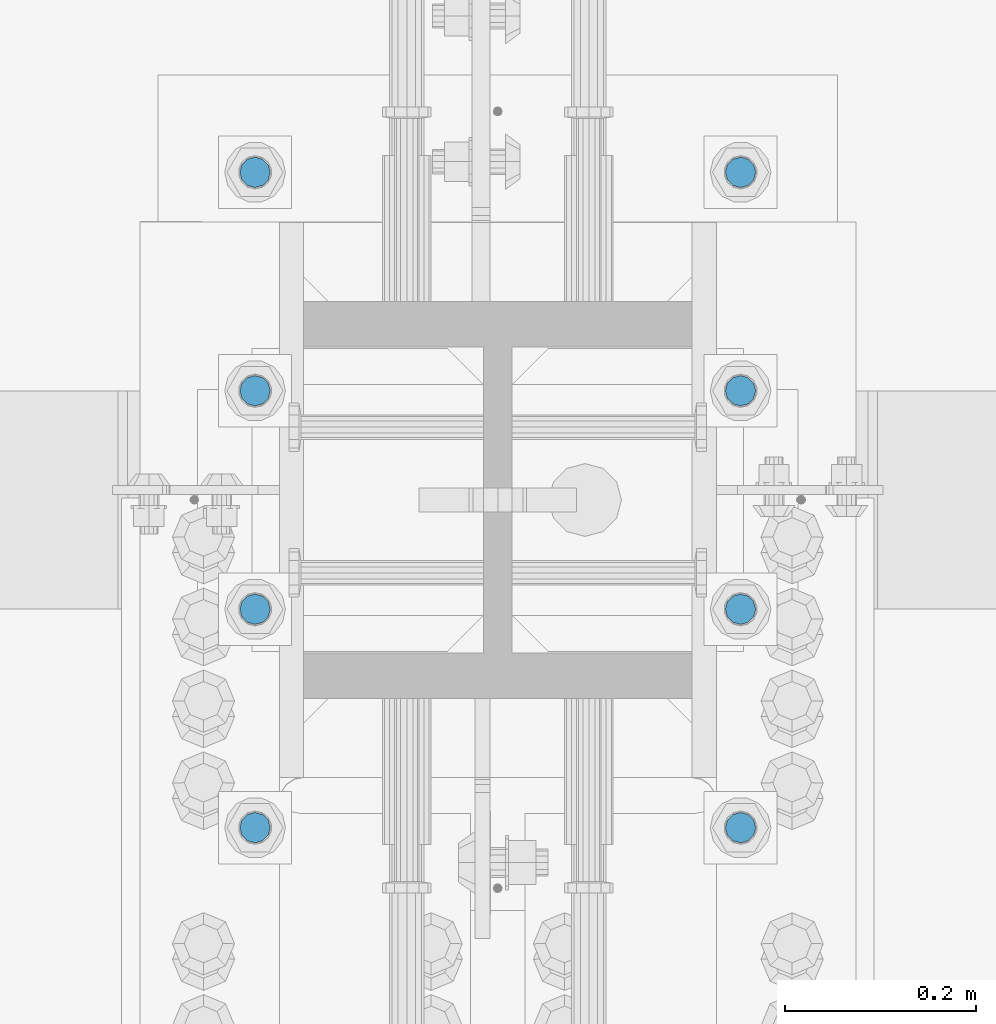
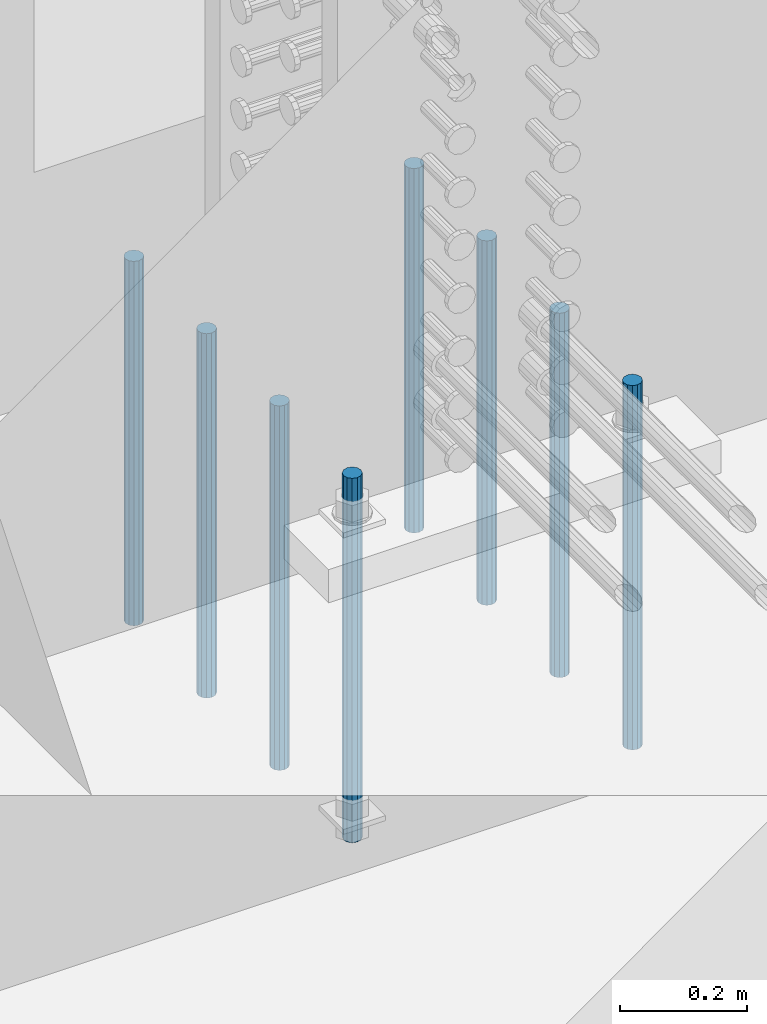
# One storey, part 939 of 1763: 8 columns, 1 element without a shape of its own.
"""IFC2X3 building model written with IfcOpenShell, lengths in millimetres."""

from ifc_helpers import new_model, si_unit, frame, origin_with_axes, place, context, subcontext, project, spatial, faceted_brep, material, type_object, element, aggregate, save


model = new_model("IFC2X3")

# Units and contexts
model_context = context("Model", 3, precision=1e-05, world=origin_with_axes())
body_context = subcontext(model_context, "Body", "Model", "MODEL_VIEW")
ifc_project = project(units=[si_unit("LENGTHUNIT", "METRE", prefix="MILLI"), si_unit("AREAUNIT", "SQUARE_METRE"), si_unit("VOLUMEUNIT", "CUBIC_METRE"), si_unit("MASSUNIT", "GRAM", prefix="KILO"), si_unit("TIMEUNIT", "SECOND"), si_unit("PLANEANGLEUNIT", "RADIAN"), si_unit("SOLIDANGLEUNIT", "STERADIAN"), si_unit("THERMODYNAMICTEMPERATUREUNIT", "DEGREE_CELSIUS"), si_unit("LUMINOUSINTENSITYUNIT", "LUMEN")], contexts=[model_context])

# Site, building, storey
site_placement = place(None, origin_with_axes())
site = spatial("IfcSite", under=ifc_project, at=site_placement, CompositionType="ELEMENT")
building_placement = place(site_placement, origin_with_axes())
building = spatial("IfcBuilding", under=site, at=building_placement, Name="Undefined", CompositionType="ELEMENT")
storey_placement = place(building_placement, origin_with_axes())
storey = spatial("IfcBuildingStorey", under=building, at=storey_placement, Name="Undefined", CompositionType="ELEMENT", Elevation=0.0)

# Assembly, columns
assembly_placement = place(storey_placement, origin_with_axes())
assembly = element("IfcElementAssembly", 1, at=assembly_placement, inside=storey, Name="TEMPLATE", AssemblyPlace="NOTDEFINED", PredefinedType="RIGID_FRAME")
ifc_material = material()
column_type = type_object("IfcColumnType", PredefinedType="NOTDEFINED")
column_1_placement = place(assembly_placement, frame((-24281.8372736984, 13347.6999999999, 4000.5), z_axis=(0.0, -1.0, 0.0), x_axis=(0.0, 0.0, -1.0)))
column_1 = element("IfcColumn", 2, at=column_1_placement, type_object=column_type, material=ifc_material, Name="ALL THREADED ROD", context=body_context, shape_type="Brep", body=[
    faceted_brep([(0.0, -15.875, 0.0), (0.0, -13.7481532850798, -7.9375), (698.499, -13.7481532850798, -7.9375), (698.499, -15.875, 0.0), (0.0, -7.9375, -13.748153285078), (698.499, -7.9375, -13.748153285078), (4.91792532185561e-12, 0.0, -15.875), (698.499, 0.0, -15.875), (0.0, 7.9375, -13.748153285078), (698.499, 7.9375, -13.748153285078), (0.0, 13.7481532850798, -7.9375), (698.499, 13.7481532850798, -7.9375), (0.0, 15.875, 0.0), (698.499, 15.875, 0.0), (0.0, 13.7481532850798, 7.9375), (698.499, 13.7481532850798, 7.9375), (0.0, 7.9375, 13.748153285078), (698.499, 7.9375, 13.748153285078), (-1.64518337079051e-12, 0.0, 15.875), (698.499, 0.0, 15.875), (0.0, -7.9375, 13.748153285078), (698.499, -7.9375, 13.748153285078), (0.0, -13.7481532850798, 7.9375), (698.499, -13.7481532850798, 7.9375)], [[[0, 1, 2, 3]], [[1, 4, 5, 2]], [[4, 6, 7, 5]], [[6, 8, 9, 7]], [[8, 10, 11, 9]], [[10, 12, 13, 11]], [[12, 14, 15, 13]], [[14, 16, 17, 15]], [[16, 18, 19, 17]], [[18, 20, 21, 19]], [[20, 22, 23, 21]], [[22, 0, 3, 23]], [[5, 7, 9, 11, 13, 15, 17, 19, 21, 23, 3, 2]], [[22, 20, 18, 16, 14, 12, 10, 8, 6, 4, 1, 0]]]),
])
column_2_placement = place(assembly_placement, frame((-23773.8372736984, 13347.6999999999, 4000.5), z_axis=(0.0, 1.0, 0.0), x_axis=(0.0, 0.0, -1.0)))
column_2 = element("IfcColumn", 3, at=column_2_placement, type_object=column_type, material=ifc_material, Name="ALL THREADED ROD", context=body_context, shape_type="Brep", body=[
    faceted_brep([(0.0, -15.875, 0.0), (0.0, -13.7481532850798, -7.9375), (698.499, -13.7481532850798, -7.9375), (698.499, -15.875, 0.0), (0.0, -7.9375, -13.748153285078), (698.499, -7.9375, -13.748153285078), (4.91792532185561e-12, 0.0, -15.875), (698.499, 0.0, -15.875), (0.0, 7.9375, -13.748153285078), (698.499, 7.9375, -13.748153285078), (0.0, 13.7481532850798, -7.9375), (698.499, 13.7481532850798, -7.9375), (0.0, 15.875, 0.0), (698.499, 15.875, 0.0), (0.0, 13.7481532850798, 7.9375), (698.499, 13.7481532850798, 7.9375), (0.0, 7.9375, 13.748153285078), (698.499, 7.9375, 13.748153285078), (-1.64518337079051e-12, 0.0, 15.875), (698.499, 0.0, 15.875), (0.0, -7.9375, 13.748153285078), (698.499, -7.9375, 13.748153285078), (0.0, -13.7481532850798, 7.9375), (698.499, -13.7481532850798, 7.9375)], [[[0, 1, 2, 3]], [[1, 4, 5, 2]], [[4, 6, 7, 5]], [[6, 8, 9, 7]], [[8, 10, 11, 9]], [[10, 12, 13, 11]], [[12, 14, 15, 13]], [[14, 16, 17, 15]], [[16, 18, 19, 17]], [[18, 20, 21, 19]], [[20, 22, 23, 21]], [[22, 0, 3, 23]], [[5, 7, 9, 11, 13, 15, 17, 19, 21, 23, 3, 2]], [[22, 20, 18, 16, 14, 12, 10, 8, 6, 4, 1, 0]]]),
])
column_3_placement = place(assembly_placement, frame((-24281.8372736984, 13576.2999999999, 4000.5), z_axis=(0.0, -1.0, 0.0), x_axis=(0.0, 0.0, -1.0)))
column_3 = element("IfcColumn", 4, at=column_3_placement, type_object=column_type, material=ifc_material, Name="ALL THREADED ROD", context=body_context, shape_type="Brep", body=[
    faceted_brep([(0.0, -15.875, 0.0), (0.0, -13.7481532850798, -7.9375), (698.499, -13.7481532850798, -7.9375), (698.499, -15.875, 0.0), (0.0, -7.9375, -13.748153285078), (698.499, -7.9375, -13.748153285078), (4.91792532185561e-12, 0.0, -15.875), (698.499, 0.0, -15.875), (0.0, 7.9375, -13.748153285078), (698.499, 7.9375, -13.748153285078), (0.0, 13.7481532850798, -7.9375), (698.499, 13.7481532850798, -7.9375), (0.0, 15.875, 0.0), (698.499, 15.875, 0.0), (0.0, 13.7481532850798, 7.9375), (698.499, 13.7481532850798, 7.9375), (0.0, 7.9375, 13.748153285078), (698.499, 7.9375, 13.748153285078), (-1.64518337079051e-12, 0.0, 15.875), (698.499, 0.0, 15.875), (0.0, -7.9375, 13.748153285078), (698.499, -7.9375, 13.748153285078), (0.0, -13.7481532850798, 7.9375), (698.499, -13.7481532850798, 7.9375)], [[[0, 1, 2, 3]], [[1, 4, 5, 2]], [[4, 6, 7, 5]], [[6, 8, 9, 7]], [[8, 10, 11, 9]], [[10, 12, 13, 11]], [[12, 14, 15, 13]], [[14, 16, 17, 15]], [[16, 18, 19, 17]], [[18, 20, 21, 19]], [[20, 22, 23, 21]], [[22, 0, 3, 23]], [[5, 7, 9, 11, 13, 15, 17, 19, 21, 23, 3, 2]], [[22, 20, 18, 16, 14, 12, 10, 8, 6, 4, 1, 0]]]),
])
column_4_placement = place(assembly_placement, frame((-23773.8372736984, 13576.2999999999, 4000.5), z_axis=(0.0, 1.0, 0.0), x_axis=(0.0, 0.0, -1.0)))
column_4 = element("IfcColumn", 5, at=column_4_placement, type_object=column_type, material=ifc_material, Name="ALL THREADED ROD", context=body_context, shape_type="Brep", body=[
    faceted_brep([(0.0, -15.875, 0.0), (0.0, -13.7481532850798, -7.9375), (698.499, -13.7481532850798, -7.9375), (698.499, -15.875, 0.0), (0.0, -7.9375, -13.748153285078), (698.499, -7.9375, -13.748153285078), (4.91792532185561e-12, 0.0, -15.875), (698.499, 0.0, -15.875), (0.0, 7.9375, -13.748153285078), (698.499, 7.9375, -13.748153285078), (0.0, 13.7481532850798, -7.9375), (698.499, 13.7481532850798, -7.9375), (0.0, 15.875, 0.0), (698.499, 15.875, 0.0), (0.0, 13.7481532850798, 7.9375), (698.499, 13.7481532850798, 7.9375), (0.0, 7.9375, 13.748153285078), (698.499, 7.9375, 13.748153285078), (-1.64518337079051e-12, 0.0, 15.875), (698.499, 0.0, 15.875), (0.0, -7.9375, 13.748153285078), (698.499, -7.9375, 13.748153285078), (0.0, -13.7481532850798, 7.9375), (698.499, -13.7481532850798, 7.9375)], [[[0, 1, 2, 3]], [[1, 4, 5, 2]], [[4, 6, 7, 5]], [[6, 8, 9, 7]], [[8, 10, 11, 9]], [[10, 12, 13, 11]], [[12, 14, 15, 13]], [[14, 16, 17, 15]], [[16, 18, 19, 17]], [[18, 20, 21, 19]], [[20, 22, 23, 21]], [[22, 0, 3, 23]], [[5, 7, 9, 11, 13, 15, 17, 19, 21, 23, 3, 2]], [[22, 20, 18, 16, 14, 12, 10, 8, 6, 4, 1, 0]]]),
])
column_5_placement = place(assembly_placement, frame((-24281.8372736984, 13804.8999999999, 4000.5), z_axis=(0.0, -1.0, 0.0), x_axis=(0.0, 0.0, -1.0)))
column_5 = element("IfcColumn", 6, at=column_5_placement, type_object=column_type, material=ifc_material, Name="ALL THREADED ROD", context=body_context, shape_type="Brep", body=[
    faceted_brep([(0.0, -15.875, 0.0), (0.0, -13.7481532850798, -7.9375), (698.499, -13.7481532850798, -7.9375), (698.499, -15.875, 0.0), (0.0, -7.9375, -13.748153285078), (698.499, -7.9375, -13.748153285078), (4.91792532185561e-12, 0.0, -15.875), (698.499, 0.0, -15.875), (0.0, 7.9375, -13.748153285078), (698.499, 7.9375, -13.748153285078), (0.0, 13.7481532850798, -7.9375), (698.499, 13.7481532850798, -7.9375), (0.0, 15.875, 0.0), (698.499, 15.875, 0.0), (0.0, 13.7481532850798, 7.9375), (698.499, 13.7481532850798, 7.9375), (0.0, 7.9375, 13.748153285078), (698.499, 7.9375, 13.748153285078), (-1.64518337079051e-12, 0.0, 15.875), (698.499, 0.0, 15.875), (0.0, -7.9375, 13.748153285078), (698.499, -7.9375, 13.748153285078), (0.0, -13.7481532850798, 7.9375), (698.499, -13.7481532850798, 7.9375)], [[[0, 1, 2, 3]], [[1, 4, 5, 2]], [[4, 6, 7, 5]], [[6, 8, 9, 7]], [[8, 10, 11, 9]], [[10, 12, 13, 11]], [[12, 14, 15, 13]], [[14, 16, 17, 15]], [[16, 18, 19, 17]], [[18, 20, 21, 19]], [[20, 22, 23, 21]], [[22, 0, 3, 23]], [[5, 7, 9, 11, 13, 15, 17, 19, 21, 23, 3, 2]], [[22, 20, 18, 16, 14, 12, 10, 8, 6, 4, 1, 0]]]),
])
column_6_placement = place(assembly_placement, frame((-23773.8372736984, 13804.8999999999, 4000.5), z_axis=(0.0, 1.0, 0.0), x_axis=(0.0, 0.0, -1.0)))
column_6 = element("IfcColumn", 7, at=column_6_placement, type_object=column_type, material=ifc_material, Name="ALL THREADED ROD", context=body_context, shape_type="Brep", body=[
    faceted_brep([(0.0, -15.875, 0.0), (0.0, -13.7481532850798, -7.9375), (698.499, -13.7481532850798, -7.9375), (698.499, -15.875, 0.0), (0.0, -7.9375, -13.748153285078), (698.499, -7.9375, -13.748153285078), (4.91792532185561e-12, 0.0, -15.875), (698.499, 0.0, -15.875), (0.0, 7.9375, -13.748153285078), (698.499, 7.9375, -13.748153285078), (0.0, 13.7481532850798, -7.9375), (698.499, 13.7481532850798, -7.9375), (0.0, 15.875, 0.0), (698.499, 15.875, 0.0), (0.0, 13.7481532850798, 7.9375), (698.499, 13.7481532850798, 7.9375), (0.0, 7.9375, 13.748153285078), (698.499, 7.9375, 13.748153285078), (-1.64518337079051e-12, 0.0, 15.875), (698.499, 0.0, 15.875), (0.0, -7.9375, 13.748153285078), (698.499, -7.9375, 13.748153285078), (0.0, -13.7481532850798, 7.9375), (698.499, -13.7481532850798, 7.9375)], [[[0, 1, 2, 3]], [[1, 4, 5, 2]], [[4, 6, 7, 5]], [[6, 8, 9, 7]], [[8, 10, 11, 9]], [[10, 12, 13, 11]], [[12, 14, 15, 13]], [[14, 16, 17, 15]], [[16, 18, 19, 17]], [[18, 20, 21, 19]], [[20, 22, 23, 21]], [[22, 0, 3, 23]], [[5, 7, 9, 11, 13, 15, 17, 19, 21, 23, 3, 2]], [[22, 20, 18, 16, 14, 12, 10, 8, 6, 4, 1, 0]]]),
])
column_7_placement = place(assembly_placement, frame((-24281.8372736984, 14033.4999999999, 4000.5), z_axis=(0.0, -1.0, 0.0), x_axis=(0.0, 0.0, -1.0)))
column_7 = element("IfcColumn", 8, at=column_7_placement, type_object=column_type, material=ifc_material, Name="ALL THREADED ROD", context=body_context, shape_type="Brep", body=[
    faceted_brep([(0.0, -15.875, 0.0), (0.0, -13.7481532850798, -7.9375), (698.499, -13.7481532850798, -7.9375), (698.499, -15.875, 0.0), (0.0, -7.9375, -13.748153285078), (698.499, -7.9375, -13.748153285078), (4.91792532185561e-12, 0.0, -15.875), (698.499, 0.0, -15.875), (0.0, 7.9375, -13.748153285078), (698.499, 7.9375, -13.748153285078), (0.0, 13.7481532850798, -7.9375), (698.499, 13.7481532850798, -7.9375), (0.0, 15.875, 0.0), (698.499, 15.875, 0.0), (0.0, 13.7481532850798, 7.9375), (698.499, 13.7481532850798, 7.9375), (0.0, 7.9375, 13.748153285078), (698.499, 7.9375, 13.748153285078), (-1.64518337079051e-12, 0.0, 15.875), (698.499, 0.0, 15.875), (0.0, -7.9375, 13.748153285078), (698.499, -7.9375, 13.748153285078), (0.0, -13.7481532850798, 7.9375), (698.499, -13.7481532850798, 7.9375)], [[[0, 1, 2, 3]], [[1, 4, 5, 2]], [[4, 6, 7, 5]], [[6, 8, 9, 7]], [[8, 10, 11, 9]], [[10, 12, 13, 11]], [[12, 14, 15, 13]], [[14, 16, 17, 15]], [[16, 18, 19, 17]], [[18, 20, 21, 19]], [[20, 22, 23, 21]], [[22, 0, 3, 23]], [[5, 7, 9, 11, 13, 15, 17, 19, 21, 23, 3, 2]], [[22, 20, 18, 16, 14, 12, 10, 8, 6, 4, 1, 0]]]),
])
column_8_placement = place(assembly_placement, frame((-23773.8372736984, 14033.4999999999, 4000.5), z_axis=(0.0, 1.0, 0.0), x_axis=(0.0, 0.0, -1.0)))
column_8 = element("IfcColumn", 9, at=column_8_placement, type_object=column_type, material=ifc_material, Name="ALL THREADED ROD", context=body_context, shape_type="Brep", body=[
    faceted_brep([(0.0, -15.875, 0.0), (0.0, -13.7481532850798, -7.9375), (698.499, -13.7481532850798, -7.9375), (698.499, -15.875, 0.0), (0.0, -7.9375, -13.748153285078), (698.499, -7.9375, -13.748153285078), (4.91792532185561e-12, 0.0, -15.875), (698.499, 0.0, -15.875), (0.0, 7.9375, -13.748153285078), (698.499, 7.9375, -13.748153285078), (0.0, 13.7481532850798, -7.9375), (698.499, 13.7481532850798, -7.9375), (0.0, 15.875, 0.0), (698.499, 15.875, 0.0), (0.0, 13.7481532850798, 7.9375), (698.499, 13.7481532850798, 7.9375), (0.0, 7.9375, 13.748153285078), (698.499, 7.9375, 13.748153285078), (-1.64518337079051e-12, 0.0, 15.875), (698.499, 0.0, 15.875), (0.0, -7.9375, 13.748153285078), (698.499, -7.9375, 13.748153285078), (0.0, -13.7481532850798, 7.9375), (698.499, -13.7481532850798, 7.9375)], [[[0, 1, 2, 3]], [[1, 4, 5, 2]], [[4, 6, 7, 5]], [[6, 8, 9, 7]], [[8, 10, 11, 9]], [[10, 12, 13, 11]], [[12, 14, 15, 13]], [[14, 16, 17, 15]], [[16, 18, 19, 17]], [[18, 20, 21, 19]], [[20, 22, 23, 21]], [[22, 0, 3, 23]], [[5, 7, 9, 11, 13, 15, 17, 19, 21, 23, 3, 2]], [[22, 20, 18, 16, 14, 12, 10, 8, 6, 4, 1, 0]]]),
])
aggregate(assembly, [column_1, column_2, column_3, column_4, column_5, column_6, column_7, column_8])

save(model, "model.ifc")
